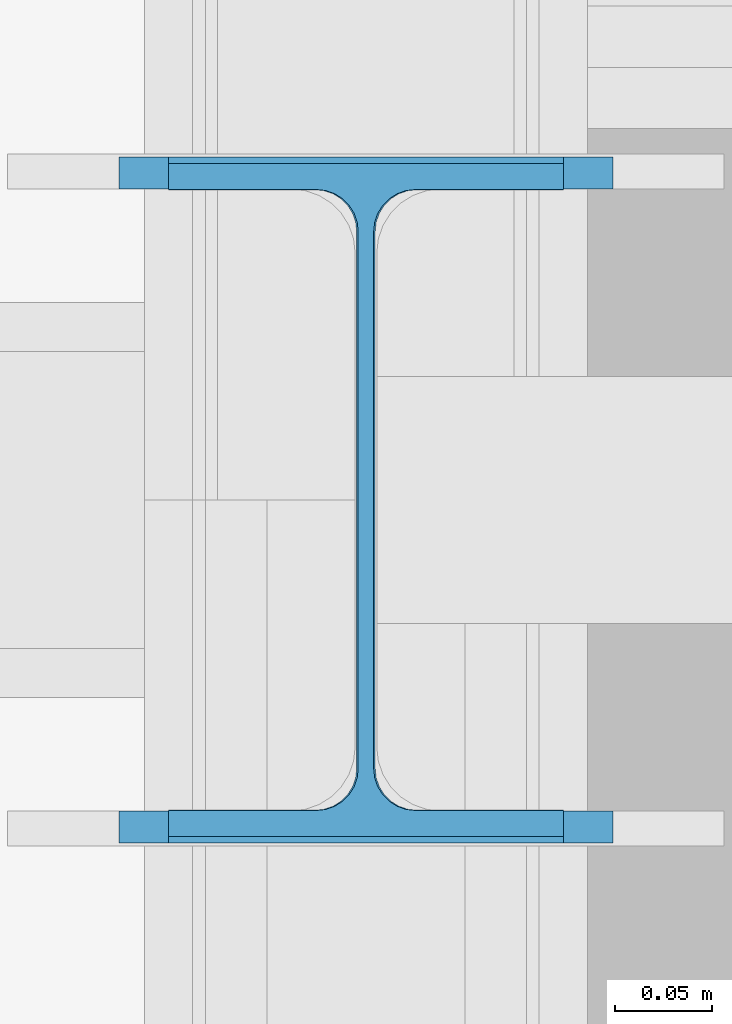
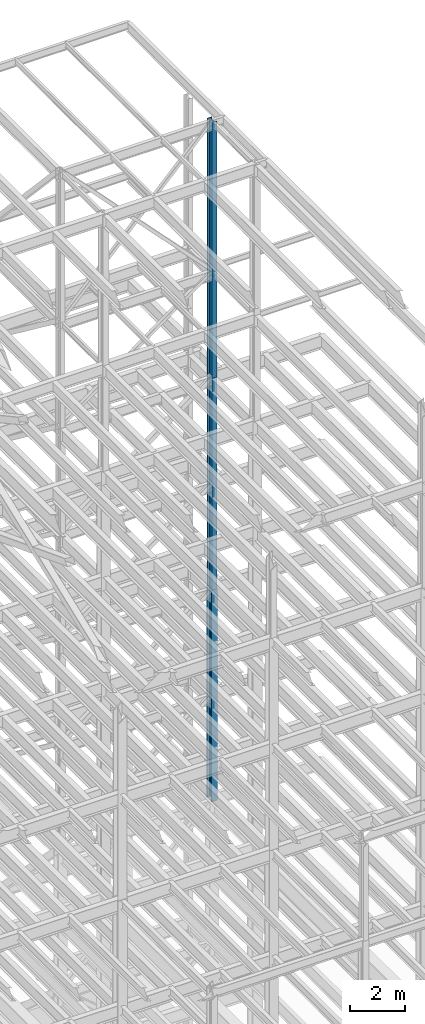
# One storey, part 118 of 150: 3 columns.
"""IFC2X3 building model written with IfcOpenShell, lengths in millimetres."""

import ifcopenshell
import ifcopenshell.guid

model = None  # the IFC model being written
_history = None  # IfcOwnerHistory: only IFC2X3 demands one
_inside = {}  # id of a spatial element -> (the spatial element, [elements in it])
_under = {}  # id of a project, library or spatial element -> (it, [spatial elements below it])
_declared = {}  # id of a project -> (the project, [libraries it declares])
_typed = {}  # id of a type object -> (the type object, [elements of that type])
_made_of = {}  # id of a material, layer set ... -> (it, [elements and type objects made of it])


def new_model(schema):
    """Start an empty IFC model of exactly this schema.

    Asked for "IFC4X3", IfcOpenShell would pick the latest addendum, in which some entities
    have other attributes; the version numbers below select the first issue.
    IFC2X3 requires an IfcOwnerHistory on every rooted entity: one is made here for all.
    """
    global model, _history
    if schema == "IFC4X3":
        model = ifcopenshell.file(schema_version=(4, 3, 0, 0))
    else:
        model = ifcopenshell.file(schema=schema)
    _inside.clear()
    _under.clear()
    _declared.clear()
    _typed.clear()
    _made_of.clear()
    _history = None
    if model.schema == "IFC2X3":
        org = make("IfcOrganization", Name="unknown")
        user = make(
            "IfcPersonAndOrganization",
            ThePerson=make("IfcPerson", FamilyName="unknown"),
            TheOrganization=org,
        )
        app = make(
            "IfcApplication",
            ApplicationDeveloper=org,
            Version="unknown",
            ApplicationFullName="unknown",
            ApplicationIdentifier="unknown",
        )
        _history = make(
            "IfcOwnerHistory",
            OwningUser=user,
            OwningApplication=app,
            ChangeAction="ADDED",
            CreationDate=0,
        )
    return model


def make(cls, **values):
    """One entity of the class cls with the attributes given. An attribute that is None is left unset."""
    return model.create_entity(
        cls, **{name: value for name, value in values.items() if value is not None}
    )


def rooted(cls, **values):
    """An entity with a GlobalId (a new one), such as an element, a storey or a relation."""
    return make(cls, GlobalId=ifcopenshell.guid.new(), OwnerHistory=_history, **values)


def si_unit(unit_type, name, prefix=None):
    """IfcSIUnit, for example si_unit("LENGTHUNIT", "METRE", prefix="MILLI")."""
    return make("IfcSIUnit", UnitType=unit_type, Prefix=prefix, Name=name)


def assignment(units):
    """IfcUnitAssignment: the units of a project."""
    return None if units is None else make("IfcUnitAssignment", Units=units)


def point(xyz):
    """IfcCartesianPoint."""
    return None if xyz is None else make("IfcCartesianPoint", Coordinates=xyz)


def direction(xyz):
    """IfcDirection."""
    return None if xyz is None else make("IfcDirection", DirectionRatios=xyz)


def frame(location, z_axis=None, x_axis=None):
    """IfcAxis2Placement3D, a coordinate frame: its origin and axes. An axis left out is left unset."""
    return make(
        "IfcAxis2Placement3D",
        Location=point(location),
        Axis=direction(z_axis),
        RefDirection=direction(x_axis),
    )


def frame_2d(location, x_axis=None):
    """IfcAxis2Placement2D, a coordinate frame in the plane: its origin and x axis."""
    return make(
        "IfcAxis2Placement2D", Location=point(location), RefDirection=direction(x_axis)
    )


def origin_with_axes():
    """The frame at (0, 0, 0) with the z axis (0, 0, 1) and the x axis (1, 0, 0) written out."""
    return frame((0.0, 0.0, 0.0), z_axis=(0.0, 0.0, 1.0), x_axis=(1.0, 0.0, 0.0))


def origin_2d_with_axis():
    """The frame at (0, 0) in the plane with the x axis (1, 0) written out."""
    return frame_2d((0.0, 0.0), x_axis=(1.0, 0.0))


def place(relative_to, where):
    """IfcLocalPlacement: puts the frame where relative to a parent placement (None: the world)."""
    return make(
        "IfcLocalPlacement", PlacementRelTo=relative_to, RelativePlacement=where
    )


def context(
    kind, dimensions, precision=None, world=None, true_north=None, identifier=None
):
    """IfcGeometricRepresentationContext, for example the 3D "Model" context."""
    return make(
        "IfcGeometricRepresentationContext",
        ContextIdentifier=identifier,
        ContextType=kind,
        CoordinateSpaceDimension=dimensions,
        Precision=precision,
        WorldCoordinateSystem=world,
        TrueNorth=true_north,
    )


def subcontext(parent, identifier, kind, view, scale=None):
    """IfcGeometricRepresentationSubContext, for example "Body" below "Model"."""
    return make(
        "IfcGeometricRepresentationSubContext",
        ContextIdentifier=identifier,
        ContextType=kind,
        ParentContext=parent,
        TargetScale=scale,
        TargetView=view,
    )


def project(units=None, contexts=None):
    """IfcProject with its units and contexts."""
    return rooted(
        "IfcProject",
        Name="project",
        RepresentationContexts=contexts,
        UnitsInContext=assignment(units),
    )


def spatial(cls, under=None, at=None, **own):
    """A site, building, storey or space (cls), placed at a placement, below another one or the project."""
    s = rooted(cls, ObjectPlacement=at, **own)
    if under is not None:
        _under.setdefault(under.id(), (under, []))[1].append(s)
    return s


def profile(cls, at=None, kind="AREA", **sizes):
    """A parametric profile (cls). Its sizes go by their IFC names, for example OverallWidth=200.0."""
    return make(cls, ProfileType=kind, Position=at, **sizes)


def i_section(**sizes):
    """IfcIShapeProfileDef."""
    return profile("IfcIShapeProfileDef", **sizes)


def extrude(swept, where, along, depth):
    """IfcExtrudedAreaSolid: the profile swept, set in the frame where, extruded along a direction by depth."""
    return make(
        "IfcExtrudedAreaSolid",
        SweptArea=swept,
        Position=where,
        ExtrudedDirection=direction(along),
        Depth=depth,
    )


def shape(context_of_items, identifier, shape_type, items):
    """IfcShapeRepresentation: the items that make up one representation, for example the "Body"."""
    return make(
        "IfcShapeRepresentation",
        ContextOfItems=context_of_items,
        RepresentationIdentifier=identifier,
        RepresentationType=shape_type,
        Items=items,
    )


def material(Name=None, Category=None):
    """IfcMaterial."""
    return make("IfcMaterial", Name=Name, Category=Category)


def made_of(thing, what):
    """Note that an element or type object is made of a material, layer set ...; save() writes the relation."""
    if what is not None:
        _made_of.setdefault(what.id(), (what, []))[1].append(thing)
    return thing


def type_object(cls, material=None, **own):
    """A type object (cls), such as IfcWallType, which elements share."""
    return made_of(rooted(cls, **own), material)


def element(
    cls,
    number,
    at=None,
    inside=None,
    cuts=None,
    type_object=None,
    material=None,
    context=None,
    identifier="Body",
    shape_type=None,
    held_by="IfcProductDefinitionShape",
    body=None,
    shapes=None,
    **own,
):
    """One element of the class cls, such as IfcWall. Its Tag is "e" and its number.

    at: its placement. inside: the storey or other place that contains it. cuts: it is an
    opening in that element (IfcRelVoidsElement). A single representation is given by context,
    identifier, shape_type and body (its items); several are given by shapes. held_by: the class
    of the entity that holds the representations. save() writes the other relations.
    """
    e = rooted(cls, Tag="e%d" % number, ObjectPlacement=at, **own)
    if body is not None:
        shapes = [shape(context, identifier, shape_type, body)]
    if shapes is not None:
        e.Representation = make(held_by, Representations=shapes)
    if inside is not None:
        _inside.setdefault(inside.id(), (inside, []))[1].append(e)
    if cuts is not None:
        rooted(
            "IfcRelVoidsElement", RelatingBuildingElement=cuts, RelatedOpeningElement=e
        )
    if type_object is not None:
        _typed.setdefault(type_object.id(), (type_object, []))[1].append(e)
    return made_of(e, material)


def aggregate(whole, parts):
    """IfcRelAggregates: a whole, such as a stair, and the parts it consists of."""
    return rooted("IfcRelAggregates", RelatingObject=whole, RelatedObjects=parts)


def save(model, path):
    """Write the relations noted so far, then the file.

    IfcRelAggregates (storeys below a building ...), IfcRelContainedInSpatialStructure (elements
    in a storey), IfcRelDefinesByType, IfcRelAssociatesMaterial and IfcRelDeclares: one each for
    every whole, place, type object, material and project.
    """
    for whole, parts in _under.values():
        aggregate(whole, parts)
    for where, things in _inside.values():
        rooted(
            "IfcRelContainedInSpatialStructure",
            RelatedElements=things,
            RelatingStructure=where,
        )
    for kind, things in _typed.values():
        rooted("IfcRelDefinesByType", RelatedObjects=things, RelatingType=kind)
    for what, things in _made_of.values():
        rooted("IfcRelAssociatesMaterial", RelatedObjects=things, RelatingMaterial=what)
    for by, libraries in _declared.values():
        rooted("IfcRelDeclares", RelatingContext=by, RelatedDefinitions=libraries)
    model.write(path)


model = new_model("IFC2X3")

# Units and contexts
model_context = context("Model", 3, precision=1e-05, world=origin_with_axes())
body_context = subcontext(model_context, "Body", "Model", "MODEL_VIEW")
ifc_project = project(units=[si_unit("LENGTHUNIT", "METRE", prefix="MILLI"), si_unit("AREAUNIT", "SQUARE_METRE"), si_unit("VOLUMEUNIT", "CUBIC_METRE"), si_unit("MASSUNIT", "GRAM", prefix="KILO"), si_unit("TIMEUNIT", "SECOND"), si_unit("PLANEANGLEUNIT", "RADIAN"), si_unit("SOLIDANGLEUNIT", "STERADIAN"), si_unit("THERMODYNAMICTEMPERATUREUNIT", "DEGREE_CELSIUS"), si_unit("LUMINOUSINTENSITYUNIT", "LUMEN")], contexts=[model_context])

# Site, building, storey
site_placement = place(None, origin_with_axes())
site = spatial("IfcSite", under=ifc_project, at=site_placement, CompositionType="ELEMENT")
building_placement = place(site_placement, origin_with_axes())
building = spatial("IfcBuilding", under=site, at=building_placement, Name="Undefined", CompositionType="ELEMENT")
storey_placement = place(building_placement, origin_with_axes())
storey = spatial("IfcBuildingStorey", under=building, at=storey_placement, Name="Undefined", CompositionType="ELEMENT", Elevation=0.0)

# Columns
ifc_material = material(Name="STEEL/A992")
column_type_1 = type_object("IfcColumnType", Name="W14X43", PredefinedType="NOTDEFINED")
column_1_placement = place(storey_placement, frame((88595.2, 25628.6, 54483.0), z_axis=(0.0, 0.0, 1.0), x_axis=(1.0, 0.0, 0.0)))
element("IfcColumn", 1, at=column_1_placement, inside=storey, type_object=column_type_1, material=ifc_material, Name="COLUMN", ObjectType="W14X43", context=body_context, shape_type="SweptSolid", body=[
    extrude(i_section(OverallWidth=203.2, OverallDepth=346.075, WebThickness=7.9375, FlangeThickness=13.462, FilletRadius=21.4629, at=origin_2d_with_axis()), frame((0.0, 0.0, 11429.998857), z_axis=(0.0, 0.0, -1.0), x_axis=(-1.0, 0.0, 0.0)), (0.0, 0.0, 1.0), 11429.998857),
])
column_type_2 = type_object("IfcColumnType", Name="W14X53", PredefinedType="NOTDEFINED")
column_2_placement = place(storey_placement, frame((88595.2, 25628.6, 45034.2), z_axis=(0.0, 0.0, 1.0), x_axis=(1.0, 0.0, 0.0)))
element("IfcColumn", 2, at=column_2_placement, inside=storey, type_object=column_type_2, material=ifc_material, Name="COLUMN", ObjectType="W14X53", context=body_context, shape_type="SweptSolid", body=[
    extrude(i_section(OverallWidth=203.2, OverallDepth=352.425, WebThickness=9.5249, FlangeThickness=16.764, FilletRadius=21.336, at=origin_2d_with_axis()), frame((0.0, 0.0, 9448.8), z_axis=(0.0, 0.0, -1.0), x_axis=(-1.0, 0.0, 0.0)), (0.0, 0.0, 1.0), 9448.8),
])
column_type_3 = type_object("IfcColumnType", Name="W14X61", PredefinedType="NOTDEFINED")
column_3_placement = place(storey_placement, frame((88595.2, 25628.6, 35585.4), z_axis=(0.0, 0.0, 1.0), x_axis=(1.0, 0.0, 0.0)))
element("IfcColumn", 3, at=column_3_placement, inside=storey, type_object=column_type_3, material=ifc_material, Name="COLUMN", ObjectType="W14X61", context=body_context, shape_type="SweptSolid", body=[
    extrude(i_section(OverallWidth=254.0, OverallDepth=352.425, WebThickness=9.5249, FlangeThickness=16.383, FilletRadius=21.717, at=origin_2d_with_axis()), frame((0.0, 0.0, 9448.8), z_axis=(0.0, 0.0, -1.0), x_axis=(-1.0, 0.0, 0.0)), (0.0, 0.0, 1.0), 9448.8),
])

save(model, "model.ifc")
